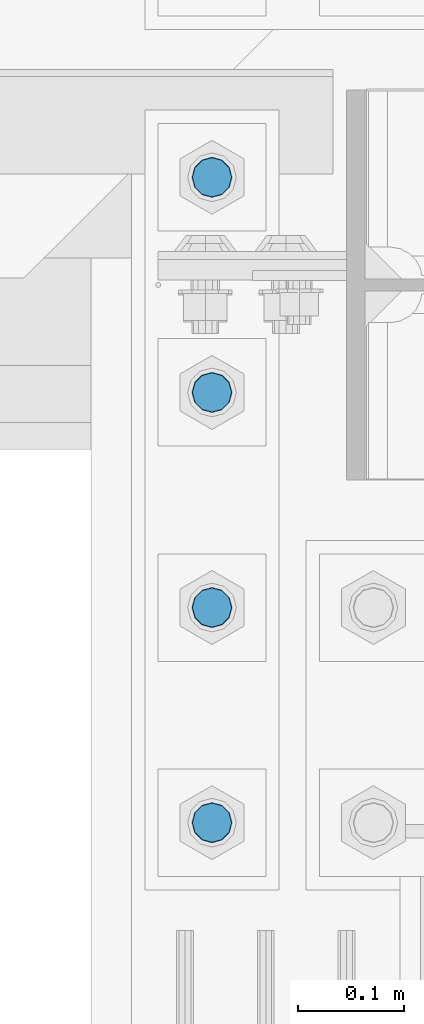
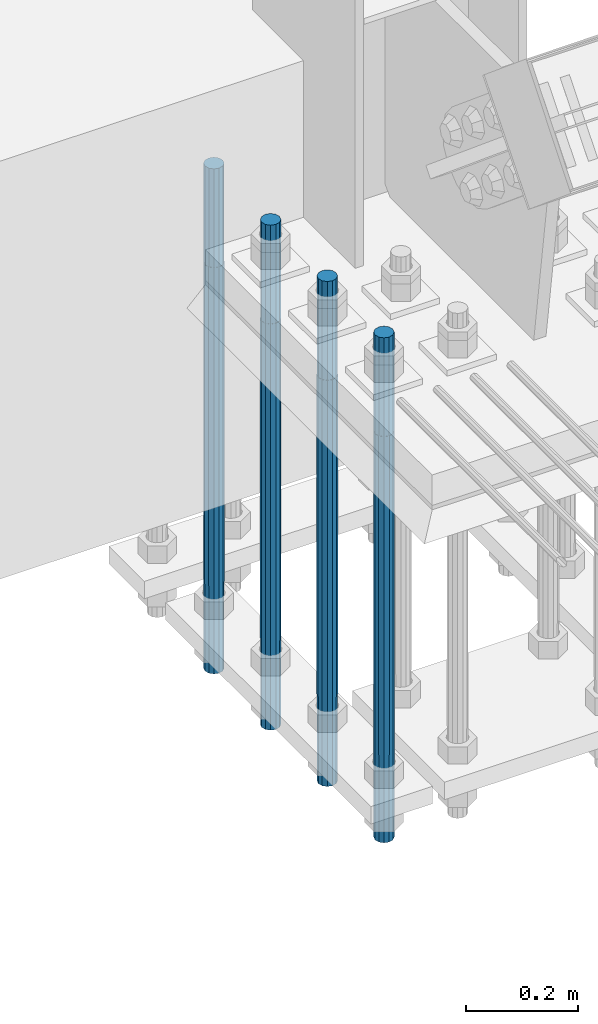
# One storey, part 1316 of 3843: 4 columns, 1 element without a shape of its own.
"""IFC2X3 building model written with IfcOpenShell, lengths in millimetres."""

from ifc_helpers import new_model, si_unit, frame, origin_with_axes, place, context, subcontext, project, spatial, faceted_brep, material, type_object, element, aggregate, save


model = new_model("IFC2X3")

# Units and contexts
model_context = context("Model", 3, precision=1e-05, world=origin_with_axes())
body_context = subcontext(model_context, "Body", "Model", "MODEL_VIEW")
ifc_project = project(units=[si_unit("LENGTHUNIT", "METRE", prefix="MILLI"), si_unit("AREAUNIT", "SQUARE_METRE"), si_unit("VOLUMEUNIT", "CUBIC_METRE"), si_unit("MASSUNIT", "GRAM", prefix="KILO"), si_unit("TIMEUNIT", "SECOND"), si_unit("PLANEANGLEUNIT", "RADIAN"), si_unit("SOLIDANGLEUNIT", "STERADIAN"), si_unit("THERMODYNAMICTEMPERATUREUNIT", "DEGREE_CELSIUS"), si_unit("LUMINOUSINTENSITYUNIT", "LUMEN")], contexts=[model_context])

# Site, building, storey
site_placement = place(None, origin_with_axes())
site = spatial("IfcSite", under=ifc_project, at=site_placement, CompositionType="ELEMENT")
building_placement = place(site_placement, origin_with_axes())
building = spatial("IfcBuilding", under=site, at=building_placement, Name="Undefined", CompositionType="ELEMENT")
storey_placement = place(building_placement, origin_with_axes())
storey = spatial("IfcBuildingStorey", under=building, at=storey_placement, Name="Undefined", CompositionType="ELEMENT", Elevation=0.0)

# Assembly, columns
assembly_placement = place(storey_placement, origin_with_axes())
assembly = element("IfcElementAssembly", 1, at=assembly_placement, inside=storey, Name="TEMPLATE", AssemblyPlace="NOTDEFINED", PredefinedType="RIGID_FRAME")
ifc_material = material(Name="Undefined/F1554-GR.55")
column_type = type_object("IfcColumnType", PredefinedType="NOTDEFINED")
column_1_placement = place(assembly_placement, frame((76708.0, 25107.9, 30022.8), z_axis=(1.0, 0.0, 0.0), x_axis=(0.0, 0.0, -1.0)))
column_1 = element("IfcColumn", 2, at=column_1_placement, type_object=column_type, material=ifc_material, Name="ANCHOR_ROD", context=body_context, shape_type="Brep", body=[
    faceted_brep([(-215.899999999998, -16.0214699700118, 9.25), (-215.899999999998, -9.25, 16.0214699700155), (-215.899999999998, 0.0, 18.5), (-215.899999999998, 9.25, 16.0214699700155), (-215.899999999998, 16.0214699700118, 9.25), (-215.899999999998, 18.5, 0.0), (-215.899999999998, 16.0214699700118, -9.25), (-215.899999999998, 9.25, -16.0214699700155), (-215.899999999998, 0.0, -18.5), (-215.899999999998, -9.25, -16.0214699700155), (-215.899999999998, -16.0214699700118, -9.25), (-215.899999999998, -18.5, 0.0), (0.0, 18.5, 0.0), (0.0, 16.0214699700118, -9.25), (0.0, 9.25, -16.0214699700155), (0.0, 0.0, -18.5), (0.0, -9.25, -16.0214699700155), (0.0, -16.0214699700118, -9.25), (0.0, -18.5, 0.0), (0.0, -16.0214699700118, 9.25), (0.0, -9.25, 16.0214699700155), (0.0, 0.0, 18.5), (0.0, 9.25, 16.0214699700155), (0.0, 16.0214699700118, 9.25), (0.0, -16.4977839420972, 9.52500000000146), (0.0, -9.52500000000146, 16.4977839420972), (0.0, 0.0, 19.0499989999989), (0.0, 9.52500000000146, 16.4977839420972), (0.0, 16.4977839420972, 9.52500000000146), (0.0, 19.0500000000029, 0.0), (0.0, 16.4977839420972, -9.52500000000146), (0.0, 9.52500000000146, -16.4977839420972), (0.0, 0.0, -19.0499989999989), (0.0, -9.52500000000146, -16.4977839420972), (0.0, -16.4977839420972, -9.52500000000146), (0.0, -19.0500000000029, 0.0), (698.5, -19.0499999999993, 0.0), (698.5, -16.4977839420935, 9.52499999999418), (698.5, -9.52500000000146, 16.4977839420899), (698.5, 0.0, 19.0500000000029), (698.5, 9.52500000000146, 16.4977839420899), (698.5, 16.4977839420935, 9.52499999999418), (698.5, 19.0499999999993, 0.0), (698.5, 16.4977839420935, -9.52499999999418), (698.5, 9.52500000000146, -16.4977839420899), (698.5, 0.0, -19.0500000000029), (698.5, -9.52500000000146, -16.4977839420899), (698.5, -16.4977839420935, -9.52499999999418), (698.5, -9.25, 16.0214699700155), (698.5, 0.0, 18.5), (698.5, 9.25, 16.0214699700155), (698.5, 16.0214699700118, 9.25), (698.5, 18.5, 0.0), (698.5, 16.0214699700118, -9.25), (698.5, 9.25, -16.0214699700155), (698.5, 0.0, -18.5), (698.5, -9.25, -16.0214699700155), (698.5, -16.0214699700118, -9.25), (698.5, -18.5, 0.0), (698.5, -16.0214699700118, 9.25), (889.0, -9.25, -16.0214699700155), (889.0, 0.0, -18.5), (889.0, 9.25, -16.0214699700155), (889.0, 16.0214699700118, -9.25), (889.0, 18.5, 0.0), (889.0, 16.0214699700118, 9.25), (889.0, 9.25, 16.0214699700155), (889.0, 0.0, 18.5), (889.0, -9.25, 16.0214699700155), (889.0, -16.0214699700118, 9.25), (889.0, -18.5, 0.0), (889.0, -16.0214699700118, -9.25)], [[[0, 1, 2, 3, 4, 5, 6, 7, 8, 9, 10, 11]], [[6, 5, 12, 13]], [[7, 6, 13, 14]], [[8, 7, 14, 15]], [[9, 8, 15, 16]], [[10, 9, 16, 17]], [[11, 10, 17, 18]], [[0, 11, 18, 19]], [[1, 0, 19, 20]], [[2, 1, 20, 21]], [[3, 2, 21, 22]], [[4, 3, 22, 23]], [[5, 4, 23, 12]], [[24, 25, 26, 27, 28, 29, 30, 31, 32, 33, 34, 35], [22, 21, 20, 19, 18, 17, 16, 15, 14, 13, 12, 23]], [[24, 35, 36, 37]], [[25, 24, 37, 38]], [[26, 25, 38, 39]], [[27, 26, 39, 40]], [[28, 27, 40, 41]], [[29, 28, 41, 42]], [[30, 29, 42, 43]], [[31, 30, 43, 44]], [[32, 31, 44, 45]], [[33, 32, 45, 46]], [[34, 33, 46, 47]], [[35, 34, 47, 36]], [[46, 45, 44, 43, 42, 41, 40, 39, 38, 37, 36, 47], [48, 49, 50, 51, 52, 53, 54, 55, 56, 57, 58, 59]], [[60, 61, 62, 63, 64, 65, 66, 67, 68, 69, 70, 71]], [[68, 67, 49, 48]], [[69, 68, 48, 59]], [[70, 69, 59, 58]], [[71, 70, 58, 57]], [[60, 71, 57, 56]], [[61, 60, 56, 55]], [[62, 61, 55, 54]], [[63, 62, 54, 53]], [[64, 63, 53, 52]], [[65, 64, 52, 51]], [[66, 65, 51, 50]], [[67, 66, 50, 49]]]),
])
column_2_placement = place(assembly_placement, frame((76708.0, 25311.1, 30022.8), z_axis=(1.0, 0.0, 0.0), x_axis=(0.0, 0.0, -1.0)))
column_2 = element("IfcColumn", 3, at=column_2_placement, type_object=column_type, material=ifc_material, Name="ANCHOR_ROD", context=body_context, shape_type="Brep", body=[
    faceted_brep([(-215.899999999998, -16.0214699700118, 9.25), (-215.899999999998, -9.25, 16.0214699700155), (-215.899999999998, 0.0, 18.5), (-215.899999999998, 9.25, 16.0214699700155), (-215.899999999998, 16.0214699700118, 9.25), (-215.899999999998, 18.5, 0.0), (-215.899999999998, 16.0214699700118, -9.25), (-215.899999999998, 9.25, -16.0214699700155), (-215.899999999998, 0.0, -18.5), (-215.899999999998, -9.25, -16.0214699700155), (-215.899999999998, -16.0214699700118, -9.25), (-215.899999999998, -18.5, 0.0), (0.0, 18.5, 0.0), (0.0, 16.0214699700118, -9.25), (0.0, 9.25, -16.0214699700155), (0.0, 0.0, -18.5), (0.0, -9.25, -16.0214699700155), (0.0, -16.0214699700118, -9.25), (0.0, -18.5, 0.0), (0.0, -16.0214699700118, 9.25), (0.0, -9.25, 16.0214699700155), (0.0, 0.0, 18.5), (0.0, 9.25, 16.0214699700155), (0.0, 16.0214699700118, 9.25), (0.0, -16.4977839420972, 9.52500000000146), (0.0, -9.52500000000146, 16.4977839420972), (0.0, 0.0, 19.0499989999989), (0.0, 9.52500000000146, 16.4977839420972), (0.0, 16.4977839420972, 9.52500000000146), (0.0, 19.0500000000029, 0.0), (0.0, 16.4977839420972, -9.52500000000146), (0.0, 9.52500000000146, -16.4977839420972), (0.0, 0.0, -19.0499989999989), (0.0, -9.52500000000146, -16.4977839420972), (0.0, -16.4977839420972, -9.52500000000146), (0.0, -19.0500000000029, 0.0), (698.5, -19.0499999999993, 0.0), (698.5, -16.4977839420935, 9.52499999999418), (698.5, -9.52500000000146, 16.4977839420899), (698.5, 0.0, 19.0500000000029), (698.5, 9.52500000000146, 16.4977839420899), (698.5, 16.4977839420935, 9.52499999999418), (698.5, 19.0499999999993, 0.0), (698.5, 16.4977839420935, -9.52499999999418), (698.5, 9.52500000000146, -16.4977839420899), (698.5, 0.0, -19.0500000000029), (698.5, -9.52500000000146, -16.4977839420899), (698.5, -16.4977839420935, -9.52499999999418), (698.5, -9.25, 16.0214699700155), (698.5, 0.0, 18.5), (698.5, 9.25, 16.0214699700155), (698.5, 16.0214699700118, 9.25), (698.5, 18.5, 0.0), (698.5, 16.0214699700118, -9.25), (698.5, 9.25, -16.0214699700155), (698.5, 0.0, -18.5), (698.5, -9.25, -16.0214699700155), (698.5, -16.0214699700118, -9.25), (698.5, -18.5, 0.0), (698.5, -16.0214699700118, 9.25), (889.0, -9.25, -16.0214699700155), (889.0, 0.0, -18.5), (889.0, 9.25, -16.0214699700155), (889.0, 16.0214699700118, -9.25), (889.0, 18.5, 0.0), (889.0, 16.0214699700118, 9.25), (889.0, 9.25, 16.0214699700155), (889.0, 0.0, 18.5), (889.0, -9.25, 16.0214699700155), (889.0, -16.0214699700118, 9.25), (889.0, -18.5, 0.0), (889.0, -16.0214699700118, -9.25)], [[[0, 1, 2, 3, 4, 5, 6, 7, 8, 9, 10, 11]], [[6, 5, 12, 13]], [[7, 6, 13, 14]], [[8, 7, 14, 15]], [[9, 8, 15, 16]], [[10, 9, 16, 17]], [[11, 10, 17, 18]], [[0, 11, 18, 19]], [[1, 0, 19, 20]], [[2, 1, 20, 21]], [[3, 2, 21, 22]], [[4, 3, 22, 23]], [[5, 4, 23, 12]], [[24, 25, 26, 27, 28, 29, 30, 31, 32, 33, 34, 35], [22, 21, 20, 19, 18, 17, 16, 15, 14, 13, 12, 23]], [[24, 35, 36, 37]], [[25, 24, 37, 38]], [[26, 25, 38, 39]], [[27, 26, 39, 40]], [[28, 27, 40, 41]], [[29, 28, 41, 42]], [[30, 29, 42, 43]], [[31, 30, 43, 44]], [[32, 31, 44, 45]], [[33, 32, 45, 46]], [[34, 33, 46, 47]], [[35, 34, 47, 36]], [[46, 45, 44, 43, 42, 41, 40, 39, 38, 37, 36, 47], [48, 49, 50, 51, 52, 53, 54, 55, 56, 57, 58, 59]], [[60, 61, 62, 63, 64, 65, 66, 67, 68, 69, 70, 71]], [[68, 67, 49, 48]], [[69, 68, 48, 59]], [[70, 69, 59, 58]], [[71, 70, 58, 57]], [[60, 71, 57, 56]], [[61, 60, 56, 55]], [[62, 61, 55, 54]], [[63, 62, 54, 53]], [[64, 63, 53, 52]], [[65, 64, 52, 51]], [[66, 65, 51, 50]], [[67, 66, 50, 49]]]),
])
column_3_placement = place(assembly_placement, frame((76708.0, 25514.3, 30022.8), z_axis=(1.0, 0.0, 0.0), x_axis=(0.0, 0.0, -1.0)))
column_3 = element("IfcColumn", 4, at=column_3_placement, type_object=column_type, material=ifc_material, Name="ANCHOR_ROD", context=body_context, shape_type="Brep", body=[
    faceted_brep([(-215.899999999998, -16.0214699700118, 9.25), (-215.899999999998, -9.25, 16.0214699700155), (-215.899999999998, 0.0, 18.5), (-215.899999999998, 9.25, 16.0214699700155), (-215.899999999998, 16.0214699700118, 9.25), (-215.899999999998, 18.5, 0.0), (-215.899999999998, 16.0214699700118, -9.25), (-215.899999999998, 9.25, -16.0214699700155), (-215.899999999998, 0.0, -18.5), (-215.899999999998, -9.25, -16.0214699700155), (-215.899999999998, -16.0214699700118, -9.25), (-215.899999999998, -18.5, 0.0), (0.0, 18.5, 0.0), (0.0, 16.0214699700118, -9.25), (0.0, 9.25, -16.0214699700155), (0.0, 0.0, -18.5), (0.0, -9.25, -16.0214699700155), (0.0, -16.0214699700118, -9.25), (0.0, -18.5, 0.0), (0.0, -16.0214699700118, 9.25), (0.0, -9.25, 16.0214699700155), (0.0, 0.0, 18.5), (0.0, 9.25, 16.0214699700155), (0.0, 16.0214699700118, 9.25), (0.0, -16.4977839420972, 9.52500000000146), (0.0, -9.52500000000146, 16.4977839420972), (0.0, 0.0, 19.0499989999989), (0.0, 9.52500000000146, 16.4977839420972), (0.0, 16.4977839420972, 9.52500000000146), (0.0, 19.0500000000029, 0.0), (0.0, 16.4977839420972, -9.52500000000146), (0.0, 9.52500000000146, -16.4977839420972), (0.0, 0.0, -19.0499989999989), (0.0, -9.52500000000146, -16.4977839420972), (0.0, -16.4977839420972, -9.52500000000146), (0.0, -19.0500000000029, 0.0), (698.5, -19.0499999999993, 0.0), (698.5, -16.4977839420935, 9.52499999999418), (698.5, -9.52500000000146, 16.4977839420899), (698.5, 0.0, 19.0500000000029), (698.5, 9.52500000000146, 16.4977839420899), (698.5, 16.4977839420935, 9.52499999999418), (698.5, 19.0499999999993, 0.0), (698.5, 16.4977839420935, -9.52499999999418), (698.5, 9.52500000000146, -16.4977839420899), (698.5, 0.0, -19.0500000000029), (698.5, -9.52500000000146, -16.4977839420899), (698.5, -16.4977839420935, -9.52499999999418), (698.5, -9.25, 16.0214699700155), (698.5, 0.0, 18.5), (698.5, 9.25, 16.0214699700155), (698.5, 16.0214699700118, 9.25), (698.5, 18.5, 0.0), (698.5, 16.0214699700118, -9.25), (698.5, 9.25, -16.0214699700155), (698.5, 0.0, -18.5), (698.5, -9.25, -16.0214699700155), (698.5, -16.0214699700118, -9.25), (698.5, -18.5, 0.0), (698.5, -16.0214699700118, 9.25), (889.0, -9.25, -16.0214699700155), (889.0, 0.0, -18.5), (889.0, 9.25, -16.0214699700155), (889.0, 16.0214699700118, -9.25), (889.0, 18.5, 0.0), (889.0, 16.0214699700118, 9.25), (889.0, 9.25, 16.0214699700155), (889.0, 0.0, 18.5), (889.0, -9.25, 16.0214699700155), (889.0, -16.0214699700118, 9.25), (889.0, -18.5, 0.0), (889.0, -16.0214699700118, -9.25)], [[[0, 1, 2, 3, 4, 5, 6, 7, 8, 9, 10, 11]], [[6, 5, 12, 13]], [[7, 6, 13, 14]], [[8, 7, 14, 15]], [[9, 8, 15, 16]], [[10, 9, 16, 17]], [[11, 10, 17, 18]], [[0, 11, 18, 19]], [[1, 0, 19, 20]], [[2, 1, 20, 21]], [[3, 2, 21, 22]], [[4, 3, 22, 23]], [[5, 4, 23, 12]], [[24, 25, 26, 27, 28, 29, 30, 31, 32, 33, 34, 35], [22, 21, 20, 19, 18, 17, 16, 15, 14, 13, 12, 23]], [[24, 35, 36, 37]], [[25, 24, 37, 38]], [[26, 25, 38, 39]], [[27, 26, 39, 40]], [[28, 27, 40, 41]], [[29, 28, 41, 42]], [[30, 29, 42, 43]], [[31, 30, 43, 44]], [[32, 31, 44, 45]], [[33, 32, 45, 46]], [[34, 33, 46, 47]], [[35, 34, 47, 36]], [[46, 45, 44, 43, 42, 41, 40, 39, 38, 37, 36, 47], [48, 49, 50, 51, 52, 53, 54, 55, 56, 57, 58, 59]], [[60, 61, 62, 63, 64, 65, 66, 67, 68, 69, 70, 71]], [[68, 67, 49, 48]], [[69, 68, 48, 59]], [[70, 69, 59, 58]], [[71, 70, 58, 57]], [[60, 71, 57, 56]], [[61, 60, 56, 55]], [[62, 61, 55, 54]], [[63, 62, 54, 53]], [[64, 63, 53, 52]], [[65, 64, 52, 51]], [[66, 65, 51, 50]], [[67, 66, 50, 49]]]),
])
column_4_placement = place(assembly_placement, frame((76708.0, 25717.5, 30022.8), z_axis=(-1.0, 0.0, 0.0), x_axis=(0.0, 0.0, -1.0)))
column_4 = element("IfcColumn", 5, at=column_4_placement, type_object=column_type, material=ifc_material, Name="ANCHOR_ROD", context=body_context, shape_type="Brep", body=[
    faceted_brep([(-215.899999999998, -16.0214699700118, 9.25), (-215.899999999998, -9.25, 16.0214699700155), (-215.899999999998, 0.0, 18.5), (-215.899999999998, 9.25, 16.0214699700155), (-215.899999999998, 16.0214699700118, 9.25), (-215.899999999998, 18.5, 0.0), (-215.899999999998, 16.0214699700118, -9.25), (-215.899999999998, 9.25, -16.0214699700155), (-215.899999999998, 0.0, -18.5), (-215.899999999998, -9.25, -16.0214699700155), (-215.899999999998, -16.0214699700118, -9.25), (-215.899999999998, -18.5, 0.0), (0.0, 18.5, 0.0), (0.0, 16.0214699700118, -9.25), (0.0, 9.25, -16.0214699700155), (0.0, 0.0, -18.5), (0.0, -9.25, -16.0214699700155), (0.0, -16.0214699700118, -9.25), (0.0, -18.5, 0.0), (0.0, -16.0214699700118, 9.25), (0.0, -9.25, 16.0214699700155), (0.0, 0.0, 18.5), (0.0, 9.25, 16.0214699700155), (0.0, 16.0214699700118, 9.25), (0.0, -16.4977839420972, 9.52500000000146), (0.0, -9.52500000000146, 16.4977839420972), (0.0, 0.0, 19.0499989999989), (0.0, 9.52500000000146, 16.4977839420972), (0.0, 16.4977839420972, 9.52500000000146), (0.0, 19.0500000000029, 0.0), (0.0, 16.4977839420972, -9.52500000000146), (0.0, 9.52500000000146, -16.4977839420972), (0.0, 0.0, -19.0499989999989), (0.0, -9.52500000000146, -16.4977839420972), (0.0, -16.4977839420972, -9.52500000000146), (0.0, -19.0500000000029, 0.0), (698.5, -19.0499999999993, 0.0), (698.5, -16.4977839420935, 9.52499999999418), (698.5, -9.52500000000146, 16.4977839420899), (698.5, 0.0, 19.0500000000029), (698.5, 9.52500000000146, 16.4977839420899), (698.5, 16.4977839420935, 9.52499999999418), (698.5, 19.0499999999993, 0.0), (698.5, 16.4977839420935, -9.52499999999418), (698.5, 9.52500000000146, -16.4977839420899), (698.5, 0.0, -19.0500000000029), (698.5, -9.52500000000146, -16.4977839420899), (698.5, -16.4977839420935, -9.52499999999418), (698.5, -9.25, 16.0214699700155), (698.5, 0.0, 18.5), (698.5, 9.25, 16.0214699700155), (698.5, 16.0214699700118, 9.25), (698.5, 18.5, 0.0), (698.5, 16.0214699700118, -9.25), (698.5, 9.25, -16.0214699700155), (698.5, 0.0, -18.5), (698.5, -9.25, -16.0214699700155), (698.5, -16.0214699700118, -9.25), (698.5, -18.5, 0.0), (698.5, -16.0214699700118, 9.25), (889.0, -9.25, -16.0214699700155), (889.0, 0.0, -18.5), (889.0, 9.25, -16.0214699700155), (889.0, 16.0214699700118, -9.25), (889.0, 18.5, 0.0), (889.0, 16.0214699700118, 9.25), (889.0, 9.25, 16.0214699700155), (889.0, 0.0, 18.5), (889.0, -9.25, 16.0214699700155), (889.0, -16.0214699700118, 9.25), (889.0, -18.5, 0.0), (889.0, -16.0214699700118, -9.25)], [[[0, 1, 2, 3, 4, 5, 6, 7, 8, 9, 10, 11]], [[6, 5, 12, 13]], [[7, 6, 13, 14]], [[8, 7, 14, 15]], [[9, 8, 15, 16]], [[10, 9, 16, 17]], [[11, 10, 17, 18]], [[0, 11, 18, 19]], [[1, 0, 19, 20]], [[2, 1, 20, 21]], [[3, 2, 21, 22]], [[4, 3, 22, 23]], [[5, 4, 23, 12]], [[24, 25, 26, 27, 28, 29, 30, 31, 32, 33, 34, 35], [22, 21, 20, 19, 18, 17, 16, 15, 14, 13, 12, 23]], [[24, 35, 36, 37]], [[25, 24, 37, 38]], [[26, 25, 38, 39]], [[27, 26, 39, 40]], [[28, 27, 40, 41]], [[29, 28, 41, 42]], [[30, 29, 42, 43]], [[31, 30, 43, 44]], [[32, 31, 44, 45]], [[33, 32, 45, 46]], [[34, 33, 46, 47]], [[35, 34, 47, 36]], [[46, 45, 44, 43, 42, 41, 40, 39, 38, 37, 36, 47], [48, 49, 50, 51, 52, 53, 54, 55, 56, 57, 58, 59]], [[60, 61, 62, 63, 64, 65, 66, 67, 68, 69, 70, 71]], [[68, 67, 49, 48]], [[69, 68, 48, 59]], [[70, 69, 59, 58]], [[71, 70, 58, 57]], [[60, 71, 57, 56]], [[61, 60, 56, 55]], [[62, 61, 55, 54]], [[63, 62, 54, 53]], [[64, 63, 53, 52]], [[65, 64, 52, 51]], [[66, 65, 51, 50]], [[67, 66, 50, 49]]]),
])
aggregate(assembly, [column_1, column_2, column_3, column_4])

save(model, "model.ifc")
